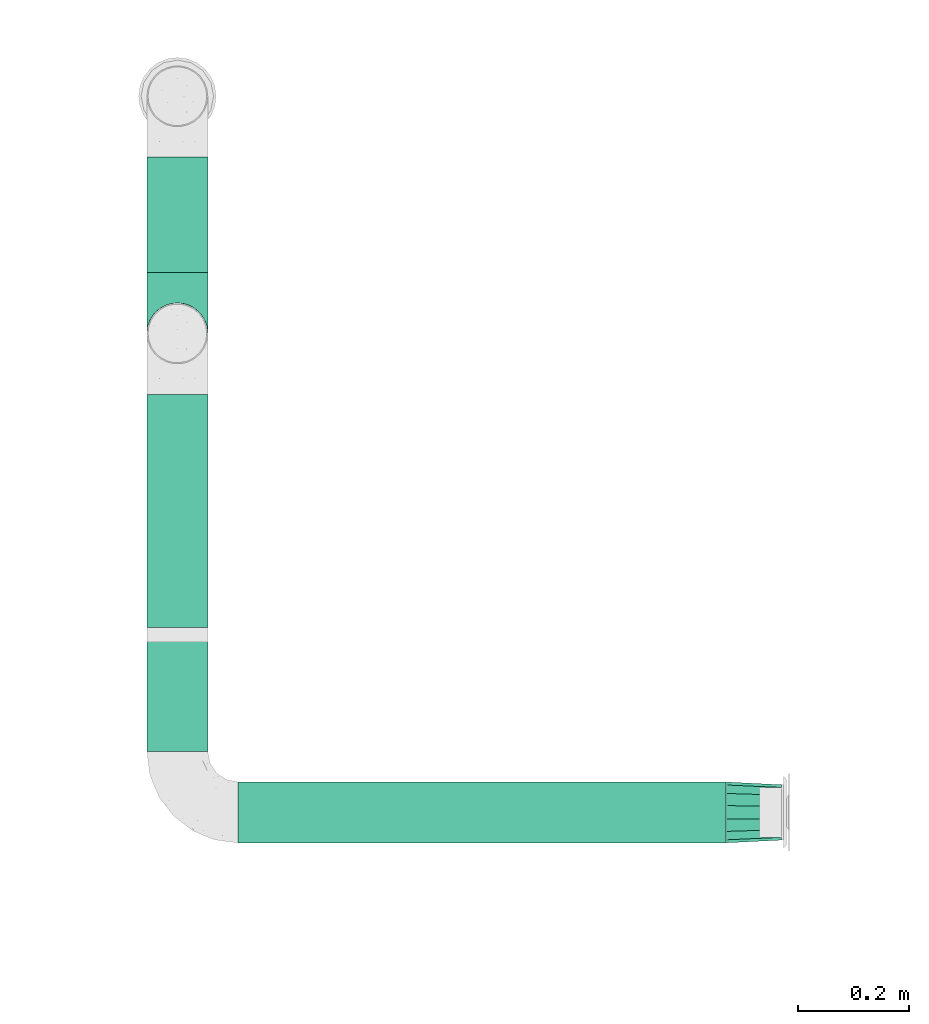
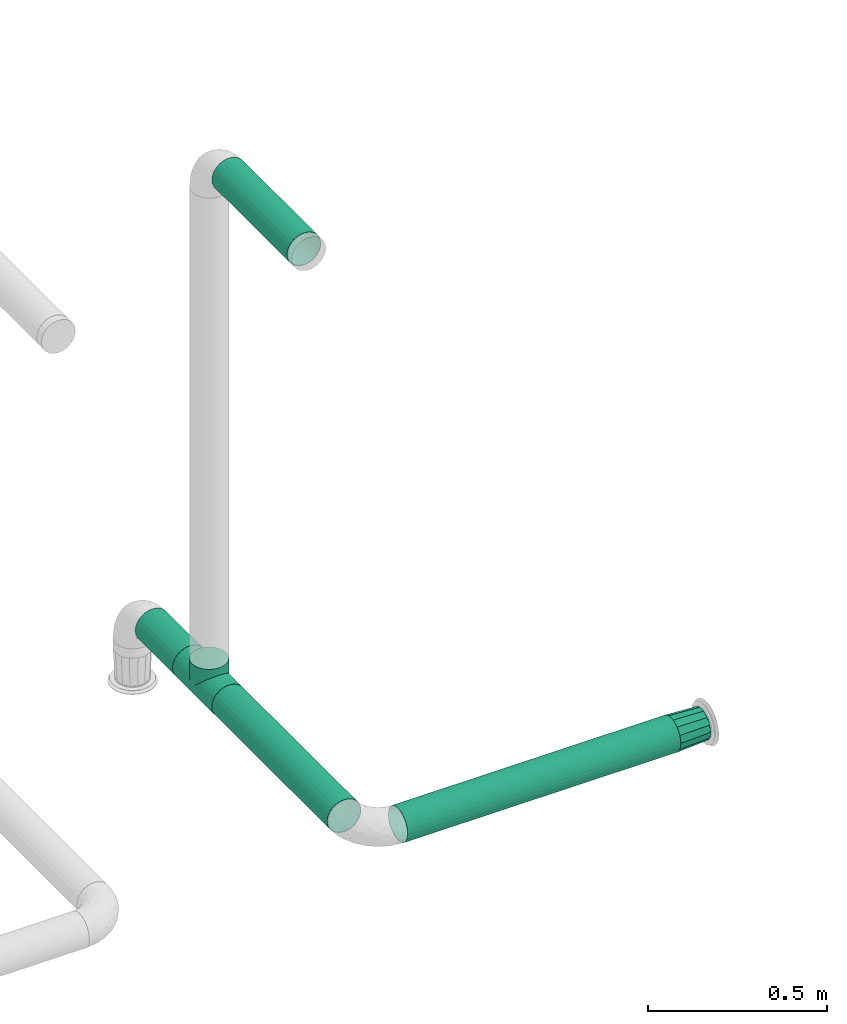
# One storey, part 26 of 103: 4 flow segments, 2 flow fittings.
"""IFC2X3 building model written with IfcOpenShell, lengths in millimetres."""

from ifc_helpers import new_model, entity, si_unit, converted_unit, derived_unit, direction, frame, origin_with_axes, origin_2d_with_axis, place, context, subcontext, project, spatial, hollow_circle, extrude, open_shell, surface_model, source, transform, mapped, material, layer, layer_set, layer_usage, type_object, element, save


model = new_model("IFC2X3")

# Units and contexts
model_context = context("Model", 3, precision=1e-05, world=origin_with_axes(), true_north=direction((0.0, 1.0)))
body_context = subcontext(model_context, "Body", "Model", "MODEL_VIEW")
ifc_project = project(units=[si_unit("AREAUNIT", "SQUARE_METRE"), si_unit("VOLUMEUNIT", "CUBIC_METRE", prefix="DECI"), si_unit("TIMEUNIT", "SECOND"), si_unit("THERMODYNAMICTEMPERATUREUNIT", "DEGREE_CELSIUS"), si_unit("PRESSUREUNIT", "PASCAL"), si_unit("MASSUNIT", "GRAM", prefix="KILO"), si_unit("LENGTHUNIT", "METRE", prefix="MILLI"), si_unit("POWERUNIT", "WATT"), si_unit("ELECTRICCURRENTUNIT", "AMPERE"), si_unit("ELECTRICVOLTAGEUNIT", "VOLT"), derived_unit("VOLUMETRICFLOWRATEUNIT", [(si_unit("VOLUMEUNIT", "CUBIC_METRE", prefix="DECI"), 1), (si_unit("TIMEUNIT", "SECOND"), -1)]), derived_unit("LINEARVELOCITYUNIT", [(si_unit("LENGTHUNIT", "METRE"), 1), (si_unit("TIMEUNIT", "SECOND"), -1)]), derived_unit("MASSDENSITYUNIT", [(si_unit("MASSUNIT", "GRAM", prefix="KILO"), 1), (si_unit("VOLUMEUNIT", "CUBIC_METRE"), -1)]), converted_unit("PLANEANGLEUNIT", "DEGREE", entity("IfcRatioMeasure", 0.01745), si_unit("PLANEANGLEUNIT", "RADIAN"), dimensions=[0, 0, 0, 0, 0, 0, 0])], contexts=[model_context])

# Site, building, storey
site_placement = place(None, origin_with_axes())
site = spatial("IfcSite", under=ifc_project, at=site_placement, CompositionType="ELEMENT")
building_placement = place(site_placement, origin_with_axes())
building = spatial("IfcBuilding", under=site, at=building_placement, Name="mc-building", CompositionType="ELEMENT")
storey_placement = place(building_placement, frame((0.0, 0.0, 5900.0), z_axis=(0.0, 0.0, 1.0), x_axis=(1.0, 0.0, 0.0)))
storey = spatial("IfcBuildingStorey", under=building, at=storey_placement, Name="3. Korrus", CompositionType="ELEMENT", Elevation=5900.0)

# Flow fitting
duct_fitting_type_1 = type_object("IfcDuctFittingType", PredefinedType="JUNCTION")
shared_shape_1 = source(origin_with_axes(), body_context, "Body", "SurfaceModel", [
    surface_model("IfcShellBasedSurfaceModel", [(0.0, -80.0, -55.0), (14.23505, -80.0, -53.12592), (-14.23505, -80.0, -53.12592), (-53.12592, -80.0, 14.23505), (-27.5, -80.0, -47.63139), (-47.63139, -80.0, -27.5), (-38.89087, -80.0, -38.89087), (55.0, -80.0, 0.0), (53.12592, -80.0, 14.23505), (38.89087, -80.0, -38.89087), (27.5, -80.0, -47.63139), (53.12592, -80.0, -14.23505), (47.63139, -80.0, -27.5), (-53.12592, -80.0, -14.23505), (-47.63139, -80.0, 27.5), (-38.89087, -80.0, 38.89087), (14.23505, -80.0, 53.12592), (-27.5, -80.0, 47.63139), (-14.23505, -80.0, 53.12592), (47.63139, -80.0, 27.5), (38.89087, -80.0, 38.89087), (27.5, -80.0, 47.63139), (0.0, -80.0, 55.0), (-55.0, -80.0, 0.0), (0.0, 0.0, 55.0), (-7.4066, -7.4066, 54.49901), (-14.74521, -14.74521, 52.98659), (-21.93978, -21.93978, 50.43457), (-28.89905, -28.89905, 46.79578), (-35.50357, -35.50357, 42.00591), (-41.58668, -41.58668, 35.99373), (-46.92319, -46.92319, 28.69171), (-51.19777, -51.19777, 20.0945), (-50.37866, -80.0, 20.86752), (-54.01174, -54.01174, 10.37938), (-55.0, -55.0, 0.0), (-54.06296, -80.0, 7.11752), (-54.01174, -54.01174, -10.37938), (-51.19777, -51.19777, -20.0945), (-54.06296, -80.0, -7.11752), (-46.92319, -46.92319, -28.69171), (-41.58668, -41.58668, -35.99373), (-50.37866, -80.0, -20.86752), (-35.50357, -35.50357, -42.00591), (-21.93978, -21.93978, -50.43457), (-14.74521, -14.74521, -52.98659), (-7.4066, -7.4066, -54.49901), (0.0, 0.0, -55.0), (-28.89905, -28.89905, -46.79578), (7.4066, -7.4066, -54.49901), (14.74521, -14.74521, -52.98659), (21.93978, -21.93978, -50.43457), (28.89905, -28.89905, -46.79578), (35.50357, -35.50357, -42.00591), (41.58668, -41.58668, -35.99373), (46.92319, -46.92319, -28.69171), (51.19777, -51.19777, -20.0945), (50.37866, -80.0, -20.86752), (54.01174, -54.01174, -10.37938), (55.0, -55.0, 0.0), (54.06296, -80.0, -7.11752), (54.01174, -54.01174, 10.37938), (51.19777, -51.19777, 20.0945), (54.06296, -80.0, 7.11752), (46.92319, -46.92319, 28.69171), (41.58668, -41.58668, 35.99373), (50.37866, -80.0, 20.86752), (35.50357, -35.50357, 42.00591), (21.93978, -21.93978, 50.43457), (14.74521, -14.74521, 52.98659), (7.4066, -7.4066, 54.49901), (28.89905, -28.89905, 46.79578), (-110.0, 0.0, -55.0), (-110.0, -14.23505, -53.12592), (-110.0, 14.23505, -53.12592), (-110.0, 53.12592, 14.23505), (-110.0, 27.5, -47.63139), (-110.0, 47.63139, -27.5), (-110.0, 38.89087, -38.89087), (-110.0, -55.0, 0.0), (-110.0, -53.12592, 14.23505), (-110.0, -38.89087, -38.89087), (-110.0, -27.5, -47.63139), (-110.0, -53.12592, -14.23505), (-110.0, -47.63139, -27.5), (-110.0, 53.12592, -14.23505), (-110.0, 47.63139, 27.5), (-110.0, 38.89087, 38.89087), (-110.0, -14.23505, 53.12592), (-110.0, 27.5, 47.63139), (-110.0, 14.23505, 53.12592), (-110.0, -47.63139, 27.5), (-110.0, -38.89087, 38.89087), (-110.0, -27.5, 47.63139), (-110.0, 0.0, 55.0), (-110.0, 55.0, 0.0), (110.0, 55.0, 0.0), (110.0, 0.0, -55.0), (110.0, 14.23505, -53.12592), (110.0, 27.5, -47.63139), (110.0, 38.89087, -38.89087), (110.0, 47.63139, -27.5), (110.0, -38.89087, -38.89087), (110.0, -53.12592, 14.23505), (110.0, -27.5, -47.63139), (110.0, -14.23505, -53.12592), (110.0, -47.63139, -27.5), (110.0, -53.12592, -14.23505), (110.0, -55.0, 0.0), (110.0, 53.12592, -14.23505), (110.0, 53.12592, 14.23505), (110.0, 47.63139, 27.5), (110.0, 38.89087, 38.89087), (110.0, 0.0, 55.0), (110.0, 27.5, 47.63139), (110.0, 14.23505, 53.12592), (110.0, -47.63139, 27.5), (110.0, -38.89087, 38.89087), (110.0, -27.5, 47.63139), (110.0, -14.23505, 53.12592)], [open_shell([[[0, 1, 2]], [[2, 3, 4]], [[5, 6, 3]], [[6, 4, 3]], [[2, 7, 8]], [[9, 7, 10]], [[1, 10, 7]], [[11, 7, 12]], [[9, 12, 7]], [[7, 2, 1]], [[5, 3, 13]], [[2, 14, 3]], [[2, 15, 14]], [[2, 16, 17]], [[17, 15, 2]], [[16, 18, 17]], [[2, 8, 19]], [[2, 19, 20]], [[2, 20, 21]], [[16, 2, 21]], [[16, 22, 18]], [[23, 13, 3]], [[24, 25, 22]], [[26, 27, 18]], [[25, 26, 18]], [[22, 25, 18]], [[17, 28, 29]], [[17, 18, 27]], [[17, 29, 15]], [[28, 17, 27]], [[30, 31, 14]], [[32, 3, 33]], [[32, 34, 3]], [[35, 36, 34]], [[31, 32, 14]], [[15, 30, 14]], [[34, 36, 3]], [[33, 14, 32]], [[36, 35, 23]], [[30, 15, 29]], [[37, 38, 13]], [[37, 13, 39]], [[40, 41, 5]], [[38, 5, 42]], [[38, 40, 5]], [[37, 39, 35]], [[35, 39, 23]], [[13, 38, 42]], [[41, 6, 5]], [[41, 43, 6]], [[44, 45, 2]], [[46, 47, 0]], [[45, 46, 2]], [[43, 48, 4]], [[44, 4, 48]], [[44, 2, 4]], [[46, 0, 2]], [[43, 4, 6]], [[47, 49, 0]], [[50, 51, 1]], [[49, 50, 1]], [[0, 49, 1]], [[10, 52, 53]], [[10, 1, 51]], [[10, 53, 9]], [[52, 10, 51]], [[54, 55, 12]], [[56, 11, 57]], [[56, 58, 11]], [[59, 60, 58]], [[55, 56, 12]], [[9, 54, 12]], [[58, 60, 11]], [[57, 12, 56]], [[60, 59, 7]], [[54, 9, 53]], [[61, 62, 8]], [[61, 8, 63]], [[64, 65, 19]], [[62, 19, 66]], [[62, 64, 19]], [[61, 63, 59]], [[7, 59, 63]], [[62, 66, 8]], [[65, 20, 19]], [[65, 67, 20]], [[68, 69, 16]], [[70, 24, 22]], [[69, 70, 16]], [[67, 71, 21]], [[68, 21, 71]], [[68, 16, 21]], [[70, 22, 16]], [[67, 21, 20]], [[72, 73, 74]], [[74, 75, 76]], [[77, 78, 75]], [[76, 75, 78]], [[74, 79, 80]], [[81, 79, 82]], [[73, 82, 79]], [[83, 79, 84]], [[81, 84, 79]], [[79, 74, 73]], [[77, 75, 85]], [[74, 86, 75]], [[74, 87, 86]], [[74, 88, 89]], [[89, 87, 74]], [[88, 90, 89]], [[74, 91, 92]], [[91, 74, 80]], [[92, 93, 74]], [[74, 93, 88]], [[88, 94, 90]], [[95, 85, 75]], [[96, 97, 98]], [[99, 96, 98]], [[96, 100, 101]], [[100, 96, 99]], [[102, 97, 103]], [[97, 102, 104]], [[104, 105, 97]], [[102, 103, 106]], [[106, 103, 107]], [[108, 107, 103]], [[109, 96, 101]], [[110, 111, 97]], [[97, 111, 112]], [[113, 97, 114]], [[97, 112, 114]], [[113, 114, 115]], [[116, 103, 97]], [[117, 116, 97]], [[118, 117, 97]], [[119, 118, 97]], [[119, 97, 113]], [[96, 110, 97]], [[24, 113, 115]], [[89, 115, 114]], [[94, 24, 90]], [[90, 24, 115]], [[115, 89, 90]], [[114, 87, 89]], [[86, 112, 111]], [[75, 111, 110]], [[95, 110, 96]], [[87, 112, 86]], [[86, 111, 75]], [[110, 95, 75]], [[112, 87, 114]], [[85, 96, 109]], [[77, 109, 101]], [[95, 96, 85]], [[85, 109, 77]], [[101, 78, 77]], [[101, 100, 78]], [[76, 100, 99]], [[74, 99, 98]], [[47, 98, 97]], [[76, 99, 74]], [[47, 72, 74]], [[98, 47, 74]], [[100, 76, 78]], [[47, 46, 72]], [[45, 44, 73]], [[46, 45, 73]], [[72, 46, 73]], [[82, 48, 43]], [[82, 73, 44]], [[82, 43, 81]], [[48, 82, 44]], [[41, 40, 84]], [[38, 37, 83]], [[40, 38, 84]], [[81, 41, 84]], [[37, 79, 83]], [[83, 84, 38]], [[79, 37, 35]], [[41, 81, 43]], [[49, 97, 105]], [[105, 104, 51]], [[53, 104, 102]], [[53, 52, 104]], [[49, 47, 97]], [[51, 50, 105]], [[52, 51, 104]], [[49, 105, 50]], [[54, 102, 106]], [[56, 106, 107]], [[58, 107, 108]], [[55, 54, 106]], [[58, 56, 107]], [[59, 58, 108]], [[55, 106, 56]], [[102, 54, 53]], [[34, 32, 80]], [[31, 30, 91]], [[32, 31, 91]], [[35, 34, 79]], [[80, 79, 34]], [[32, 91, 80]], [[30, 92, 91]], [[30, 29, 92]], [[27, 26, 88]], [[25, 24, 94]], [[26, 25, 88]], [[29, 28, 93]], [[27, 93, 28]], [[27, 88, 93]], [[25, 94, 88]], [[29, 93, 92]], [[61, 108, 103]], [[62, 103, 116]], [[65, 116, 117]], [[61, 59, 108]], [[64, 62, 116]], [[65, 64, 116]], [[61, 103, 62]], [[117, 67, 65]], [[71, 67, 118]], [[118, 67, 117]], [[68, 118, 119]], [[70, 119, 113]], [[68, 71, 118]], [[70, 69, 119]], [[24, 70, 113]], [[68, 119, 69]]])]),
])
flow_fitting_1_placement = place(storey_placement, frame((16394.13313, 4302.28735, 2345.0), z_axis=(-1.0, 0.0, 0.0), x_axis=(0.0, 1.0, 0.0)))
element("IfcFlowFitting", 1, at=flow_fitting_1_placement, inside=storey, type_object=duct_fitting_type_1, context=body_context, shape_type="MappedRepresentation", body=[
    mapped(shared_shape_1, transform((0.0, 0.0, 0.0), scale=1.0)),
])

# Flow segments
ifc_material = material(Name="FZ1")
ifc_layer = layer(ifc_material, 0.0)
ifc_layer_set = layer_set([ifc_layer], Name="FZ1")
ifc_layer_usage = layer_usage(ifc_layer_set, "AXIS1", "POSITIVE", 0.0)
duct_segment_type = type_object("IfcDuctSegmentType", Name="Safe", PredefinedType="RIGIDSEGMENT")
shared_shape_2 = source(origin_with_axes(), body_context, "Body", "SweptSolid", [
    extrude(hollow_circle(Radius=55.0, WallThickness=2.0, at=origin_2d_with_axis()), frame((0.0, 0.0, 0.0), z_axis=(1.0, 0.0, 0.0), x_axis=(0.0, 1.0, 0.0)), (0.0, 0.0, 1.0), 881.8),
])
flow_segment_1_placement = place(storey_placement, frame((16504.13313, 3436.80698, 2345.0), z_axis=(0.0, 0.0, 1.0), x_axis=(1.0, 0.0, 0.0)))
element("IfcFlowSegment", 2, at=flow_segment_1_placement, inside=storey, type_object=duct_segment_type, material=ifc_layer_usage, Name="Safe", context=body_context, shape_type="MappedRepresentation", body=[
    mapped(shared_shape_2, transform((0.0, 0.0, 0.0), scale=1.0)),
])
shared_shape_3 = source(origin_with_axes(), body_context, "Body", "SweptSolid", [
    extrude(hollow_circle(Radius=55.0, WallThickness=2.0, at=origin_2d_with_axis()), frame((0.0, 0.0, 0.0), z_axis=(1.0, 0.0, 0.0), x_axis=(0.0, 1.0, 0.0)), (0.0, 0.0, 1.0), 208.6),
])
flow_segment_2_placement = place(storey_placement, frame((16394.13313, 4412.28735, 2345.0), z_axis=(0.0, 0.0, 1.0), x_axis=(0.0, 1.0, 0.0)))
element("IfcFlowSegment", 3, at=flow_segment_2_placement, inside=storey, type_object=duct_segment_type, material=ifc_layer_usage, Name="Safe", context=body_context, shape_type="MappedRepresentation", body=[
    mapped(shared_shape_3, transform((0.0, 0.0, 0.0), scale=1.0)),
])

# Flow fitting
duct_fitting_type_2 = type_object("IfcDuctFittingType", PredefinedType="TRANSITION")
shared_shape_4 = source(origin_with_axes(), body_context, "Body", "SurfaceModel", [
    surface_model("IfcShellBasedSurfaceModel", [(0.0, -53.12592, -14.23505), (2.0, -53.12592, -14.23505), (0.0, -55.0, 0.0), (0.0, -47.63139, -27.5), (2.0, -47.63139, -27.5), (2.0, -27.5, -47.63139), (0.0, -38.89087, -38.89087), (0.0, -27.5, -47.63139), (2.0, -38.89087, -38.89087), (2.0, -14.23505, -53.12592), (0.0, -14.23505, -53.12592), (2.0, -55.0, 0.0), (2.0, 0.0, -55.0), (0.0, 0.0, -55.0), (0.0, 14.23505, -53.12592), (2.0, 14.23505, -53.12592), (0.0, 27.5, -47.63139), (2.0, 27.5, -47.63139), (2.0, 47.63139, -27.5), (0.0, 38.89087, -38.89087), (0.0, 47.63139, -27.5), (2.0, 38.89087, -38.89087), (2.0, 53.12592, -14.23505), (0.0, 53.12592, -14.23505), (2.0, 55.0, 0.0), (0.0, 55.0, 0.0), (0.0, 53.12592, 14.23505), (2.0, 53.12592, 14.23505), (0.0, 47.63139, 27.5), (2.0, 47.63139, 27.5), (2.0, 27.5, 47.63139), (0.0, 38.89087, 38.89087), (0.0, 27.5, 47.63139), (2.0, 38.89087, 38.89087), (2.0, 14.23505, 53.12592), (0.0, 14.23505, 53.12592), (2.0, 0.0, 55.0), (0.0, 0.0, 55.0), (0.0, -14.23505, 53.12592), (2.0, -14.23505, 53.12592), (0.0, -27.5, 47.63139), (2.0, -27.5, 47.63139), (2.0, -47.63139, 27.5), (0.0, -38.89087, 38.89087), (0.0, -47.63139, 27.5), (2.0, -38.89087, 38.89087), (2.0, -53.12592, 14.23505), (0.0, -53.12592, 14.23505), (0.0, -49.55329, 23.86361), (0.0, 34.29194, 43.00073), (0.0, 49.55329, 23.86361), (0.0, -12.23865, -53.62104), (0.0, -34.29194, -43.00073), (0.0, 12.23865, -53.62104), (100.0, 11.12605, 48.7464), (100.0, -11.12605, 48.7464), (100.0, -31.17449, 39.09157), (100.0, 50.0, 0.0), (100.0, -45.04844, 21.69419), (100.0, 31.17449, 39.09157), (100.0, 45.04844, 21.69419), (100.0, 11.12605, -48.7464), (100.0, -45.04844, -21.69419), (100.0, -31.17449, -39.09157), (100.0, -11.12605, -48.7464), (100.0, 31.17449, -39.09157), (100.0, 45.04844, -21.69419), (100.0, -50.0, 0.0), (0.0, -12.23865, 53.62104), (0.0, 12.23865, 53.62104), (0.0, -34.29194, 43.00073), (0.0, 34.29194, -43.00073), (0.0, 49.55329, -23.86361), (0.0, -49.55329, -23.86361), (100.0, 47.52422, -10.84709), (100.0, 38.11147, -30.39288), (0.0, 23.2653, -48.31088), (0.0, 0.0, -53.62104), (0.0, 41.92261, -33.43217), (100.0, 0.0, -48.7464), (0.0, 52.32388, -11.72483), (100.0, 21.15027, -43.91899), (0.0, -23.2653, -48.31088), (0.0, -52.32388, -11.72483), (0.0, -41.92261, -33.43217), (100.0, -38.11147, -30.39288), (100.0, -47.52422, -10.84709), (100.0, -21.15027, -43.91899), (100.0, -47.52422, 10.84709), (100.0, -38.11147, 30.39288), (0.0, -23.2653, 48.31088), (0.0, 0.0, 53.62104), (0.0, -41.92261, 33.43217), (100.0, 0.0, 48.7464), (0.0, -52.32388, 11.72483), (100.0, -21.15027, 43.91899), (0.0, 23.2653, 48.31088), (0.0, 52.32388, 11.72483), (0.0, 41.92261, 33.43217), (100.0, 38.11147, 30.39288), (100.0, 47.52422, 10.84709), (100.0, 21.15027, 43.91899), (100.0, 12.94095, -48.29629), (100.0, 25.0, -43.30127), (100.0, 35.35534, -35.35534), (100.0, 43.30127, -25.0), (100.0, 48.29629, -12.94095), (100.0, 0.0, -50.0), (100.0, -25.0, -43.30127), (100.0, -12.94095, -48.29629), (100.0, -35.35534, -35.35534), (100.0, -48.29629, -12.94095), (100.0, -43.30127, -25.0), (100.0, -48.29629, 12.94095), (100.0, 48.29629, 12.94095), (100.0, 43.30127, 25.0), (100.0, 35.35534, 35.35534), (100.0, 12.94095, 48.29629), (100.0, 0.0, 50.0), (100.0, 25.0, 43.30127), (100.0, -35.35534, 35.35534), (100.0, -43.30127, 25.0), (100.0, -12.94095, 48.29629), (100.0, -25.0, 43.30127), (98.0, 48.29629, 12.94095), (98.0, 0.0, 50.0), (98.0, 12.94095, 48.29629), (98.0, 25.0, 43.30127), (98.0, 35.35534, 35.35534), (98.0, 43.30127, 25.0), (98.0, -35.35534, 35.35534), (98.0, -12.94095, 48.29629), (98.0, -25.0, 43.30127), (98.0, -48.29629, 12.94095), (98.0, -43.30127, 25.0), (98.0, -25.0, -43.30127), (98.0, -48.29629, -12.94095), (98.0, -50.0, 0.0), (98.0, 48.29629, -12.94095), (98.0, 12.94095, -48.29629), (98.0, 43.30127, -25.0), (98.0, 35.35534, -35.35534), (98.0, 25.0, -43.30127), (98.0, -35.35534, -35.35534), (98.0, -43.30127, -25.0), (98.0, -12.94095, -48.29629), (98.0, 0.0, -50.0), (98.0, 50.0, 0.0)], [open_shell([[[0, 1, 2]], [[3, 4, 0]], [[5, 6, 7]], [[3, 6, 8]], [[9, 7, 10]], [[0, 4, 1]], [[1, 11, 2]], [[9, 5, 7]], [[8, 6, 5]], [[8, 4, 3]], [[12, 9, 10]], [[10, 13, 12]], [[14, 15, 13]], [[16, 17, 14]], [[18, 19, 20]], [[16, 19, 21]], [[22, 20, 23]], [[16, 21, 17]], [[17, 15, 14]], [[24, 22, 23]], [[18, 20, 22]], [[18, 21, 19]], [[25, 24, 23]], [[13, 15, 12]], [[26, 27, 25]], [[28, 29, 26]], [[30, 31, 32]], [[28, 31, 33]], [[34, 32, 35]], [[26, 29, 27]], [[27, 24, 25]], [[34, 30, 32]], [[33, 31, 30]], [[33, 29, 28]], [[36, 34, 35]], [[35, 37, 36]], [[38, 39, 37]], [[40, 41, 38]], [[42, 43, 44]], [[40, 43, 45]], [[46, 44, 47]], [[40, 45, 41]], [[41, 39, 38]], [[11, 46, 47]], [[42, 44, 46]], [[42, 45, 43]], [[2, 11, 47]], [[37, 39, 36]], [[0, 2, 3]], [[48, 49, 50]], [[50, 2, 48]], [[51, 52, 2]], [[51, 2, 53]], [[37, 35, 32]], [[38, 37, 32]], [[38, 32, 28]], [[28, 32, 31]], [[7, 44, 28]], [[38, 43, 40]], [[38, 28, 43]], [[44, 2, 47]], [[43, 28, 44]], [[44, 3, 2]], [[25, 28, 26]], [[25, 23, 20]], [[25, 20, 16]], [[25, 16, 13]], [[16, 20, 19]], [[13, 16, 14]], [[3, 7, 6]], [[7, 13, 10]], [[3, 44, 7]], [[13, 7, 25]], [[28, 25, 7]], [[17, 12, 15]], [[21, 5, 17]], [[5, 18, 22]], [[21, 18, 5]], [[24, 5, 22]], [[12, 5, 9]], [[12, 17, 5]], [[5, 4, 8]], [[5, 24, 4]], [[11, 1, 4]], [[4, 24, 27]], [[29, 11, 27]], [[30, 29, 33]], [[30, 34, 36]], [[29, 30, 11]], [[36, 42, 30]], [[11, 42, 46]], [[11, 30, 42]], [[36, 41, 45]], [[45, 42, 36]], [[41, 36, 39]], [[27, 11, 4]], [[54, 55, 56]], [[57, 56, 58]], [[59, 54, 57]], [[57, 60, 59]], [[54, 56, 57]], [[58, 61, 57]], [[62, 63, 58]], [[64, 58, 63]], [[57, 65, 66]], [[57, 61, 65]], [[64, 61, 58]], [[62, 58, 67]], [[68, 69, 49]], [[68, 49, 70]], [[70, 49, 48]], [[50, 71, 2]], [[72, 71, 50]], [[71, 53, 2]], [[73, 2, 52]], [[25, 72, 50]], [[72, 74, 66]], [[75, 65, 71]], [[65, 76, 71]], [[77, 53, 61]], [[66, 78, 72]], [[79, 51, 77]], [[80, 57, 74]], [[78, 66, 75]], [[75, 71, 78]], [[81, 53, 76]], [[81, 61, 53]], [[51, 79, 64]], [[64, 82, 51]], [[67, 2, 83]], [[62, 73, 84]], [[84, 63, 85]], [[52, 63, 84]], [[67, 83, 86]], [[57, 80, 25]], [[87, 52, 82]], [[72, 80, 74]], [[86, 73, 62]], [[84, 85, 62]], [[76, 65, 81]], [[87, 63, 52]], [[77, 61, 79]], [[73, 86, 83]], [[82, 64, 87]], [[48, 88, 58]], [[89, 56, 70]], [[56, 90, 70]], [[91, 68, 55]], [[58, 92, 48]], [[93, 69, 91]], [[94, 67, 88]], [[92, 58, 89]], [[89, 70, 92]], [[95, 68, 90]], [[95, 55, 68]], [[69, 93, 54]], [[54, 96, 69]], [[57, 25, 97]], [[60, 50, 98]], [[98, 59, 99]], [[49, 59, 98]], [[57, 97, 100]], [[67, 94, 2]], [[101, 49, 96]], [[48, 94, 88]], [[100, 50, 60]], [[98, 99, 60]], [[90, 56, 95]], [[101, 59, 49]], [[91, 55, 93]], [[50, 100, 97]], [[96, 54, 101]], [[102, 103, 104]], [[102, 104, 105]], [[102, 106, 107]], [[106, 102, 105]], [[107, 106, 57]], [[107, 108, 109]], [[107, 57, 108]], [[110, 111, 112]], [[111, 110, 108]], [[108, 113, 111]], [[108, 57, 114]], [[114, 115, 116]], [[114, 116, 117]], [[117, 118, 114]], [[117, 116, 119]], [[114, 118, 120]], [[113, 120, 121]], [[67, 111, 113]], [[120, 122, 123]], [[108, 120, 113]], [[118, 122, 120]], [[108, 114, 120]], [[124, 125, 126]], [[124, 126, 127]], [[128, 129, 124]], [[128, 124, 127]], [[125, 124, 130]], [[131, 130, 132]], [[131, 125, 130]], [[130, 133, 134]], [[133, 130, 135]], [[136, 137, 133]], [[135, 130, 124]], [[124, 138, 135]], [[139, 138, 140]], [[141, 142, 139]], [[141, 139, 140]], [[135, 138, 139]], [[136, 143, 144]], [[143, 136, 135]], [[139, 145, 135]], [[136, 133, 135]], [[146, 145, 139]], [[138, 124, 147]], [[136, 111, 137]], [[144, 112, 136]], [[108, 143, 135]], [[144, 143, 110]], [[109, 135, 145]], [[136, 112, 111]], [[111, 67, 137]], [[109, 108, 135]], [[110, 143, 108]], [[110, 112, 144]], [[107, 109, 145]], [[145, 146, 107]], [[139, 102, 146]], [[142, 103, 139]], [[105, 141, 140]], [[142, 141, 104]], [[106, 140, 138]], [[142, 104, 103]], [[103, 102, 139]], [[57, 106, 138]], [[105, 140, 106]], [[105, 104, 141]], [[147, 57, 138]], [[146, 102, 107]], [[124, 114, 147]], [[129, 115, 124]], [[119, 128, 127]], [[129, 128, 116]], [[117, 127, 126]], [[124, 115, 114]], [[114, 57, 147]], [[117, 119, 127]], [[116, 128, 119]], [[116, 115, 129]], [[118, 117, 126]], [[126, 125, 118]], [[131, 122, 125]], [[132, 123, 131]], [[121, 130, 134]], [[132, 130, 120]], [[113, 134, 133]], [[132, 120, 123]], [[123, 122, 131]], [[67, 113, 133]], [[121, 134, 113]], [[121, 120, 130]], [[137, 67, 133]], [[125, 122, 118]]])]),
])
flow_fitting_2_placement = place(storey_placement, frame((17385.97051, 3436.80698, 2345.0), z_axis=(0.0, 0.0, 1.0), x_axis=(1.0, 0.0, 0.0)))
element("IfcFlowFitting", 4, at=flow_fitting_2_placement, inside=storey, type_object=duct_fitting_type_2, context=body_context, shape_type="MappedRepresentation", body=[
    mapped(shared_shape_4, transform((0.0, 0.0, 0.0), scale=1.0)),
])

# Flow segments
shared_shape_5 = source(origin_with_axes(), body_context, "Body", "SweptSolid", [
    extrude(hollow_circle(Radius=55.0, WallThickness=2.0, at=origin_2d_with_axis()), frame((0.0, 0.0, 0.0), z_axis=(1.0, 0.0, 0.0), x_axis=(0.0, 1.0, 0.0)), (0.0, 0.0, 1.0), 645.5),
])
flow_segment_3_placement = place(storey_placement, frame((16394.13313, 3546.80698, 2345.0), z_axis=(0.0, 0.0, 1.0), x_axis=(0.0, 1.0, 0.0)))
element("IfcFlowSegment", 5, at=flow_segment_3_placement, inside=storey, type_object=duct_segment_type, material=ifc_layer_usage, Name="Safe", context=body_context, shape_type="MappedRepresentation", body=[
    mapped(shared_shape_5, transform((0.0, 0.0, 0.0), scale=1.0)),
])
shared_shape_6 = source(origin_with_axes(), body_context, "Body", "SweptSolid", [
    extrude(hollow_circle(Radius=55.0, WallThickness=2.0, at=origin_2d_with_axis()), frame((0.0, 0.0, 0.0), z_axis=(1.0, 0.0, 0.0), x_axis=(0.0, 1.0, 0.0)), (0.0, 0.0, 1.0), 421.1),
])
flow_segment_4_placement = place(storey_placement, frame((16394.13313, 3771.20513, 4144.0), z_axis=(0.0, 0.0, 1.0), x_axis=(0.0, 1.0, 0.0)))
element("IfcFlowSegment", 6, at=flow_segment_4_placement, inside=storey, type_object=duct_segment_type, material=ifc_layer_usage, Name="Safe", context=body_context, shape_type="MappedRepresentation", body=[
    mapped(shared_shape_6, transform((0.0, 0.0, 0.0), scale=1.0)),
])

save(model, "model.ifc")
